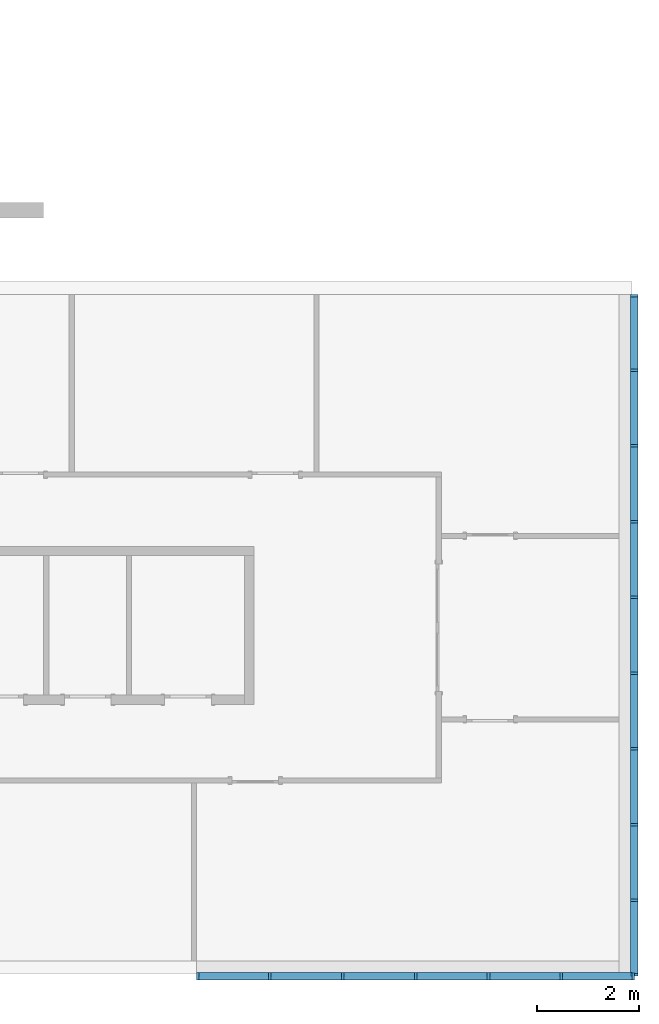
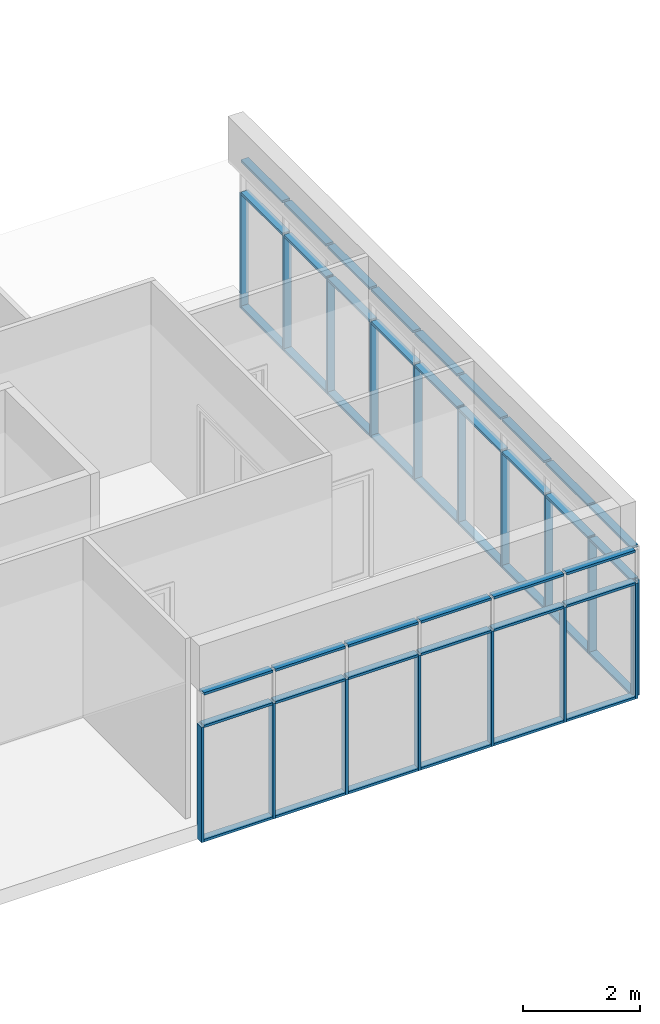
# One storey, part 2 of 11: 62 members, 2 elements without a shape of their own.
"""IFC2X3 building model written with IfcOpenShell, lengths in millimetres."""

import ifcopenshell
import ifcopenshell.guid

model = None  # the IFC model being written
_history = None  # IfcOwnerHistory: only IFC2X3 demands one
_inside = {}  # id of a spatial element -> (the spatial element, [elements in it])
_under = {}  # id of a project, library or spatial element -> (it, [spatial elements below it])
_declared = {}  # id of a project -> (the project, [libraries it declares])
_typed = {}  # id of a type object -> (the type object, [elements of that type])
_made_of = {}  # id of a material, layer set ... -> (it, [elements and type objects made of it])


def new_model(schema):
    """Start an empty IFC model of exactly this schema.

    Asked for "IFC4X3", IfcOpenShell would pick the latest addendum, in which some entities
    have other attributes; the version numbers below select the first issue.
    IFC2X3 requires an IfcOwnerHistory on every rooted entity: one is made here for all.
    """
    global model, _history
    if schema == "IFC4X3":
        model = ifcopenshell.file(schema_version=(4, 3, 0, 0))
    else:
        model = ifcopenshell.file(schema=schema)
    _inside.clear()
    _under.clear()
    _declared.clear()
    _typed.clear()
    _made_of.clear()
    _history = None
    if model.schema == "IFC2X3":
        org = make("IfcOrganization", Name="unknown")
        user = make(
            "IfcPersonAndOrganization",
            ThePerson=make("IfcPerson", FamilyName="unknown"),
            TheOrganization=org,
        )
        app = make(
            "IfcApplication",
            ApplicationDeveloper=org,
            Version="unknown",
            ApplicationFullName="unknown",
            ApplicationIdentifier="unknown",
        )
        _history = make(
            "IfcOwnerHistory",
            OwningUser=user,
            OwningApplication=app,
            ChangeAction="ADDED",
            CreationDate=0,
        )
    return model


def make(cls, **values):
    """One entity of the class cls with the attributes given. An attribute that is None is left unset."""
    return model.create_entity(
        cls, **{name: value for name, value in values.items() if value is not None}
    )


def entity(cls, *values):
    """Any entity or typed value of the class cls, its attributes in the order of the schema. None: left unset."""
    e = model.create_entity(cls)
    for i, value in enumerate(values):
        if value is not None:
            e[i] = value
    return e


def rooted(cls, **values):
    """An entity with a GlobalId (a new one), such as an element, a storey or a relation."""
    return make(cls, GlobalId=ifcopenshell.guid.new(), OwnerHistory=_history, **values)


def si_unit(unit_type, name, prefix=None):
    """IfcSIUnit, for example si_unit("LENGTHUNIT", "METRE", prefix="MILLI")."""
    return make("IfcSIUnit", UnitType=unit_type, Prefix=prefix, Name=name)


def converted_unit(unit_type, name, factor, base, dimensions=None, offset=None):
    """IfcConversionBasedUnit, such as the inch: factor (a typed value) times the base unit."""
    return make(
        "IfcConversionBasedUnit"
        if offset is None
        else "IfcConversionBasedUnitWithOffset",
        ConversionOffset=offset,
        Dimensions=None
        if dimensions is None
        else entity("IfcDimensionalExponents", *dimensions),
        UnitType=unit_type,
        Name=name,
        ConversionFactor=make(
            "IfcMeasureWithUnit", ValueComponent=factor, UnitComponent=base
        ),
    )


def assignment(units):
    """IfcUnitAssignment: the units of a project."""
    return None if units is None else make("IfcUnitAssignment", Units=units)


def point(xyz):
    """IfcCartesianPoint."""
    return None if xyz is None else make("IfcCartesianPoint", Coordinates=xyz)


def direction(xyz):
    """IfcDirection."""
    return None if xyz is None else make("IfcDirection", DirectionRatios=xyz)


def frame(location, z_axis=None, x_axis=None):
    """IfcAxis2Placement3D, a coordinate frame: its origin and axes. An axis left out is left unset."""
    return make(
        "IfcAxis2Placement3D",
        Location=point(location),
        Axis=direction(z_axis),
        RefDirection=direction(x_axis),
    )


def frame_2d(location, x_axis=None):
    """IfcAxis2Placement2D, a coordinate frame in the plane: its origin and x axis."""
    return make(
        "IfcAxis2Placement2D", Location=point(location), RefDirection=direction(x_axis)
    )


def origin():
    """The frame at (0, 0, 0) with its axes left unset."""
    return frame((0.0, 0.0, 0.0))


def origin_2d_with_axis():
    """The frame at (0, 0) in the plane with the x axis (1, 0) written out."""
    return frame_2d((0.0, 0.0), x_axis=(1.0, 0.0))


def place(relative_to, where):
    """IfcLocalPlacement: puts the frame where relative to a parent placement (None: the world)."""
    return make(
        "IfcLocalPlacement", PlacementRelTo=relative_to, RelativePlacement=where
    )


def context(
    kind, dimensions, precision=None, world=None, true_north=None, identifier=None
):
    """IfcGeometricRepresentationContext, for example the 3D "Model" context."""
    return make(
        "IfcGeometricRepresentationContext",
        ContextIdentifier=identifier,
        ContextType=kind,
        CoordinateSpaceDimension=dimensions,
        Precision=precision,
        WorldCoordinateSystem=world,
        TrueNorth=true_north,
    )


def subcontext(parent, identifier, kind, view, scale=None):
    """IfcGeometricRepresentationSubContext, for example "Body" below "Model"."""
    return make(
        "IfcGeometricRepresentationSubContext",
        ContextIdentifier=identifier,
        ContextType=kind,
        ParentContext=parent,
        TargetScale=scale,
        TargetView=view,
    )


def project(units=None, contexts=None):
    """IfcProject with its units and contexts."""
    return rooted(
        "IfcProject",
        Name="project",
        RepresentationContexts=contexts,
        UnitsInContext=assignment(units),
    )


def spatial(cls, under=None, at=None, **own):
    """A site, building, storey or space (cls), placed at a placement, below another one or the project."""
    s = rooted(cls, ObjectPlacement=at, **own)
    if under is not None:
        _under.setdefault(under.id(), (under, []))[1].append(s)
    return s


def profile(cls, at=None, kind="AREA", **sizes):
    """A parametric profile (cls). Its sizes go by their IFC names, for example OverallWidth=200.0."""
    return make(cls, ProfileType=kind, Position=at, **sizes)


def rectangle(**sizes):
    """IfcRectangleProfileDef."""
    return profile("IfcRectangleProfileDef", **sizes)


def extrude(swept, where, along, depth):
    """IfcExtrudedAreaSolid: the profile swept, set in the frame where, extruded along a direction by depth."""
    return make(
        "IfcExtrudedAreaSolid",
        SweptArea=swept,
        Position=where,
        ExtrudedDirection=direction(along),
        Depth=depth,
    )


def shape(context_of_items, identifier, shape_type, items):
    """IfcShapeRepresentation: the items that make up one representation, for example the "Body"."""
    return make(
        "IfcShapeRepresentation",
        ContextOfItems=context_of_items,
        RepresentationIdentifier=identifier,
        RepresentationType=shape_type,
        Items=items,
    )


def made_of(thing, what):
    """Note that an element or type object is made of a material, layer set ...; save() writes the relation."""
    if what is not None:
        _made_of.setdefault(what.id(), (what, []))[1].append(thing)
    return thing


def element(
    cls,
    number,
    at=None,
    inside=None,
    cuts=None,
    type_object=None,
    material=None,
    context=None,
    identifier="Body",
    shape_type=None,
    held_by="IfcProductDefinitionShape",
    body=None,
    shapes=None,
    **own,
):
    """One element of the class cls, such as IfcWall. Its Tag is "e" and its number.

    at: its placement. inside: the storey or other place that contains it. cuts: it is an
    opening in that element (IfcRelVoidsElement). A single representation is given by context,
    identifier, shape_type and body (its items); several are given by shapes. held_by: the class
    of the entity that holds the representations. save() writes the other relations.
    """
    e = rooted(cls, Tag="e%d" % number, ObjectPlacement=at, **own)
    if body is not None:
        shapes = [shape(context, identifier, shape_type, body)]
    if shapes is not None:
        e.Representation = make(held_by, Representations=shapes)
    if inside is not None:
        _inside.setdefault(inside.id(), (inside, []))[1].append(e)
    if cuts is not None:
        rooted(
            "IfcRelVoidsElement", RelatingBuildingElement=cuts, RelatedOpeningElement=e
        )
    if type_object is not None:
        _typed.setdefault(type_object.id(), (type_object, []))[1].append(e)
    return made_of(e, material)


def aggregate(whole, parts):
    """IfcRelAggregates: a whole, such as a stair, and the parts it consists of."""
    return rooted("IfcRelAggregates", RelatingObject=whole, RelatedObjects=parts)


def save(model, path):
    """Write the relations noted so far, then the file.

    IfcRelAggregates (storeys below a building ...), IfcRelContainedInSpatialStructure (elements
    in a storey), IfcRelDefinesByType, IfcRelAssociatesMaterial and IfcRelDeclares: one each for
    every whole, place, type object, material and project.
    """
    for whole, parts in _under.values():
        aggregate(whole, parts)
    for where, things in _inside.values():
        rooted(
            "IfcRelContainedInSpatialStructure",
            RelatedElements=things,
            RelatingStructure=where,
        )
    for kind, things in _typed.values():
        rooted("IfcRelDefinesByType", RelatedObjects=things, RelatingType=kind)
    for what, things in _made_of.values():
        rooted("IfcRelAssociatesMaterial", RelatedObjects=things, RelatingMaterial=what)
    for by, libraries in _declared.values():
        rooted("IfcRelDeclares", RelatingContext=by, RelatedDefinitions=libraries)
    model.write(path)


model = new_model("IFC2X3")

# Units and contexts
model_context = context("Model", 3, precision=1e-06, world=origin(), true_north=direction((2.0, 6.12303176911189e-17, 1.0)))
context_of_model = context(None, 3, precision=1e-06, world=origin(), true_north=direction((2.0, 6.12303176911189e-17, 1.0)))
body_context = subcontext(model_context, "Body", "Model", "MODEL_VIEW")
ifc_project = project(units=[si_unit("LENGTHUNIT", "METRE", prefix="MILLI"), si_unit("AREAUNIT", "SQUARE_METRE", prefix="MILLI"), si_unit("VOLUMEUNIT", "CUBIC_METRE", prefix="MILLI"), converted_unit("PLANEANGLEUNIT", "DEGREE", entity("IfcRatioMeasure", 0.0174532925199433), si_unit("PLANEANGLEUNIT", "RADIAN"), dimensions=[0, 0, 0, 0, 0, 0, 0]), si_unit("TIMEUNIT", "SECOND")], contexts=[model_context, context_of_model])

# Site, building, storey
site_placement = place(None, origin())
site = spatial("IfcSite", under=ifc_project, at=site_placement, CompositionType="ELEMENT")
building_placement = place(site_placement, origin())
building = spatial("IfcBuilding", under=site, at=building_placement, CompositionType="ELEMENT")
storey_placement = place(building_placement, frame((0.0, 0.0, 3750.0)))
storey = spatial("IfcBuildingStorey", under=building, at=storey_placement, Name="02. 2 etg.", CompositionType="ELEMENT", Elevation=3750.00000000068)

# Curtain wall, members
curtain_wall_1_placement = place(storey_placement, origin())
curtain_wall_1 = element("IfcCurtainWall", 1, at=curtain_wall_1_placement, inside=storey, Name="Curtain Wall:Storefront", ObjectType="Curtain Wall:Storefront")
member_1_placement = place(storey_placement, origin())
member_1 = element("IfcMember", 2, at=member_1_placement, Name="Curtain Wall:Storefront:8486", ObjectType="Curtain Wall:Storefront:8486", context=body_context, shape_type="SweptSolid", body=[
    extrude(rectangle(XDim=1411.66666666667, YDim=150.000000000001, at=frame_2d((0.0, 4.32720526077901e-12), x_axis=(1.0, 0.0))), frame((41098.2357123495, -12684.1666666667, 2750.0), z_axis=(0.0, 0.0, 1.0), x_axis=(0.0, 1.0, 0.0)), (0.0, 0.0, 1.0), 49.9999999999995),
])
member_2_placement = place(storey_placement, origin())
member_2 = element("IfcMember", 3, at=member_2_placement, Name="Curtain Wall:Storefront:8486", ObjectType="Curtain Wall:Storefront:8486", context=body_context, shape_type="SweptSolid", body=[
    extrude(rectangle(XDim=1411.66666666667, YDim=150.000000000001, at=origin_2d_with_axis()), frame((41098.2357123495, -815.833333333333, -300.0), z_axis=(0.0, 0.0, 1.0), x_axis=(0.0, -1.0, 0.0)), (0.0, 0.0, 1.0), 50.0),
])
member_3_placement = place(storey_placement, origin())
member_3 = element("IfcMember", 4, at=member_3_placement, Name="Curtain Wall:Storefront:8486", ObjectType="Curtain Wall:Storefront:8486", context=body_context, shape_type="SweptSolid", body=[
    extrude(rectangle(XDim=150.000000000001, YDim=50.0000000000016, at=origin_2d_with_axis()), frame((41098.2357123495, -13415.0, -300.0)), (0.0, 0.0, 1.0), 2400.0),
])
member_4_placement = place(storey_placement, origin())
member_4 = element("IfcMember", 5, at=member_4_placement, Name="Curtain Wall:Storefront:8486", ObjectType="Curtain Wall:Storefront:8486", context=body_context, shape_type="SweptSolid", body=[
    extrude(rectangle(XDim=1411.66666666667, YDim=150.000000000001, at=origin_2d_with_axis()), frame((41098.2357123495, -815.83333333333, 2750.0), z_axis=(0.0, 0.0, 1.0), x_axis=(0.0, 1.0, 0.0)), (0.0, 0.0, 1.0), 49.9999999999995),
])
member_5_placement = place(storey_placement, origin())
member_5 = element("IfcMember", 6, at=member_5_placement, Name="Curtain Wall:Storefront:8486", ObjectType="Curtain Wall:Storefront:8486", context=body_context, shape_type="SweptSolid", body=[
    extrude(rectangle(XDim=1436.66666666667, YDim=150.000000000001, at=frame_2d((0.0, 4.32720526077901e-12), x_axis=(1.0, 0.0))), frame((41098.2357123495, -2290.0, 2750.0), z_axis=(0.0, 0.0, 1.0), x_axis=(0.0, 1.0, 0.0)), (0.0, 0.0, 1.0), 49.9999999999995),
])
member_6_placement = place(storey_placement, origin())
member_6 = element("IfcMember", 7, at=member_6_placement, Name="Curtain Wall:Storefront:8486", ObjectType="Curtain Wall:Storefront:8486", context=body_context, shape_type="SweptSolid", body=[
    extrude(rectangle(XDim=1436.66666666667, YDim=150.000000000001, at=origin_2d_with_axis()), frame((41098.2357123495, -3776.66666666667, 2750.0), z_axis=(0.0, 0.0, 1.0), x_axis=(0.0, 1.0, 0.0)), (0.0, 0.0, 1.0), 49.9999999999995),
])
member_7_placement = place(storey_placement, origin())
member_7 = element("IfcMember", 8, at=member_7_placement, Name="Curtain Wall:Storefront:8486", ObjectType="Curtain Wall:Storefront:8486", context=body_context, shape_type="SweptSolid", body=[
    extrude(rectangle(XDim=1436.66666666667, YDim=150.000000000001, at=frame_2d((-5.11590769747272e-13, 0.0), x_axis=(1.0, 0.0))), frame((41098.2357123495, -5263.33333333333, 2750.0), z_axis=(0.0, 0.0, 1.0), x_axis=(0.0, 1.0, 0.0)), (0.0, 0.0, 1.0), 49.9999999999995),
])
member_8_placement = place(storey_placement, origin())
member_8 = element("IfcMember", 9, at=member_8_placement, Name="Curtain Wall:Storefront:8486", ObjectType="Curtain Wall:Storefront:8486", context=body_context, shape_type="SweptSolid", body=[
    extrude(rectangle(XDim=1436.66666666667, YDim=150.000000000001, at=frame_2d((-5.11590769747272e-13, 0.0), x_axis=(1.0, 0.0))), frame((41098.2357123495, -6750.0, 2750.0), z_axis=(0.0, 0.0, 1.0), x_axis=(0.0, 1.0, 0.0)), (0.0, 0.0, 1.0), 49.9999999999995),
])
member_9_placement = place(storey_placement, origin())
member_9 = element("IfcMember", 10, at=member_9_placement, Name="Curtain Wall:Storefront:8486", ObjectType="Curtain Wall:Storefront:8486", context=body_context, shape_type="SweptSolid", body=[
    extrude(rectangle(XDim=1436.66666666667, YDim=150.000000000001, at=frame_2d((5.6843418860808e-13, -4.32720526077901e-12), x_axis=(1.0, 0.0))), frame((41098.2357123495, -8236.66666666667, 2750.0), z_axis=(0.0, 0.0, 1.0), x_axis=(0.0, 1.0, 0.0)), (0.0, 0.0, 1.0), 49.9999999999995),
])
member_10_placement = place(storey_placement, origin())
member_10 = element("IfcMember", 11, at=member_10_placement, Name="Curtain Wall:Storefront:8486", ObjectType="Curtain Wall:Storefront:8486", context=body_context, shape_type="SweptSolid", body=[
    extrude(rectangle(XDim=1436.66666666667, YDim=150.000000000001, at=frame_2d((-5.11590769747272e-13, 0.0), x_axis=(1.0, 0.0))), frame((41098.2357123495, -9723.33333333333, 2750.0), z_axis=(0.0, 0.0, 1.0), x_axis=(0.0, 1.0, 0.0)), (0.0, 0.0, 1.0), 49.9999999999995),
])
member_11_placement = place(storey_placement, origin())
member_11 = element("IfcMember", 12, at=member_11_placement, Name="Curtain Wall:Storefront:8486", ObjectType="Curtain Wall:Storefront:8486", context=body_context, shape_type="SweptSolid", body=[
    extrude(rectangle(XDim=1436.66666666667, YDim=150.000000000001, at=origin_2d_with_axis()), frame((41098.2357123495, -11210.0, 2750.0), z_axis=(0.0, 0.0, 1.0), x_axis=(0.0, 1.0, 0.0)), (0.0, 0.0, 1.0), 49.9999999999995),
])
member_12_placement = place(storey_placement, origin())
member_12 = element("IfcMember", 13, at=member_12_placement, Name="Curtain Wall:Storefront:8486", ObjectType="Curtain Wall:Storefront:8486", context=body_context, shape_type="SweptSolid", body=[
    extrude(rectangle(XDim=1436.66666666667, YDim=150.000000000001, at=frame_2d((0.0, -4.32720526077901e-12), x_axis=(1.0, 0.0))), frame((41098.2357123495, -2290.0, -300.0), z_axis=(0.0, 0.0, 1.0), x_axis=(0.0, -1.0, 0.0)), (0.0, 0.0, 1.0), 50.0),
])
member_13_placement = place(storey_placement, origin())
member_13 = element("IfcMember", 14, at=member_13_placement, Name="Curtain Wall:Storefront:8486", ObjectType="Curtain Wall:Storefront:8486", context=body_context, shape_type="SweptSolid", body=[
    extrude(rectangle(XDim=1436.66666666667, YDim=150.000000000001, at=origin_2d_with_axis()), frame((41098.2357123495, -3776.66666666667, -300.0), z_axis=(0.0, 0.0, 1.0), x_axis=(0.0, -1.0, 0.0)), (0.0, 0.0, 1.0), 50.0),
])
member_14_placement = place(storey_placement, origin())
member_14 = element("IfcMember", 15, at=member_14_placement, Name="Curtain Wall:Storefront:8486", ObjectType="Curtain Wall:Storefront:8486", context=body_context, shape_type="SweptSolid", body=[
    extrude(rectangle(XDim=1436.66666666667, YDim=150.000000000001, at=origin_2d_with_axis()), frame((41098.2357123495, -5263.33333333333, -300.0), z_axis=(0.0, 0.0, 1.0), x_axis=(0.0, -1.0, 0.0)), (0.0, 0.0, 1.0), 50.0),
])
member_15_placement = place(storey_placement, origin())
member_15 = element("IfcMember", 16, at=member_15_placement, Name="Curtain Wall:Storefront:8486", ObjectType="Curtain Wall:Storefront:8486", context=body_context, shape_type="SweptSolid", body=[
    extrude(rectangle(XDim=1436.66666666667, YDim=150.000000000001, at=origin_2d_with_axis()), frame((41098.2357123495, -6750.0, -300.0), z_axis=(0.0, 0.0, 1.0), x_axis=(0.0, -1.0, 0.0)), (0.0, 0.0, 1.0), 50.0),
])
member_16_placement = place(storey_placement, origin())
member_16 = element("IfcMember", 17, at=member_16_placement, Name="Curtain Wall:Storefront:8486", ObjectType="Curtain Wall:Storefront:8486", context=body_context, shape_type="SweptSolid", body=[
    extrude(rectangle(XDim=1436.66666666667, YDim=150.000000000001, at=frame_2d((5.11590769747272e-13, 4.32720526077901e-12), x_axis=(1.0, 0.0))), frame((41098.2357123495, -8236.66666666667, -300.0), z_axis=(0.0, 0.0, 1.0), x_axis=(0.0, -1.0, 0.0)), (0.0, 0.0, 1.0), 50.0),
])
member_17_placement = place(storey_placement, origin())
member_17 = element("IfcMember", 18, at=member_17_placement, Name="Curtain Wall:Storefront:8486", ObjectType="Curtain Wall:Storefront:8486", context=body_context, shape_type="SweptSolid", body=[
    extrude(rectangle(XDim=1436.66666666667, YDim=150.000000000001, at=frame_2d((1.08002495835535e-12, 0.0), x_axis=(1.0, 0.0))), frame((41098.2357123495, -9723.33333333333, -300.0), z_axis=(0.0, 0.0, 1.0), x_axis=(0.0, -1.0, 0.0)), (0.0, 0.0, 1.0), 50.0),
])
member_18_placement = place(storey_placement, origin())
member_18 = element("IfcMember", 19, at=member_18_placement, Name="Curtain Wall:Storefront:8486", ObjectType="Curtain Wall:Storefront:8486", context=body_context, shape_type="SweptSolid", body=[
    extrude(rectangle(XDim=1436.66666666667, YDim=150.000000000001, at=frame_2d((-1.08002495835535e-12, 0.0), x_axis=(1.0, 0.0))), frame((41098.2357123495, -11210.0, -300.0), z_axis=(0.0, 0.0, 1.0), x_axis=(0.0, -1.0, 0.0)), (0.0, 0.0, 1.0), 50.0),
])
member_19_placement = place(storey_placement, origin())
member_19 = element("IfcMember", 20, at=member_19_placement, Name="Curtain Wall:Storefront:8486", ObjectType="Curtain Wall:Storefront:8486", context=body_context, shape_type="SweptSolid", body=[
    extrude(rectangle(XDim=1411.66666666667, YDim=150.000000000001, at=frame_2d((0.0, -4.32720526077901e-12), x_axis=(1.0, 0.0))), frame((41098.2357123495, -12684.1666666667, -300.0), z_axis=(0.0, 0.0, 1.0), x_axis=(0.0, -1.0, 0.0)), (0.0, 0.0, 1.0), 50.0),
])
member_20_placement = place(storey_placement, origin())
member_20 = element("IfcMember", 21, at=member_20_placement, Name="Curtain Wall:Storefront:8486", ObjectType="Curtain Wall:Storefront:8486", context=body_context, shape_type="SweptSolid", body=[
    extrude(rectangle(XDim=50.0, YDim=150.000000000001, at=frame_2d((3.5527136788005e-15, 0.0), x_axis=(1.0, 0.0))), frame((41098.2357123495, -85.0, -300.0), z_axis=(0.0, 0.0, 1.0), x_axis=(0.0, -1.0, 0.0)), (0.0, 0.0, 1.0), 2400.0),
])
member_21_placement = place(storey_placement, origin())
member_21 = element("IfcMember", 22, at=member_21_placement, Name="Curtain Wall:Storefront:8486", ObjectType="Curtain Wall:Storefront:8486", context=body_context, shape_type="SweptSolid", body=[
    extrude(rectangle(XDim=1411.66666666667, YDim=150.000000000001, at=origin_2d_with_axis()), frame((41098.2357123495, -815.833333333332, 2075.0), z_axis=(0.0, 0.0, 1.0), x_axis=(0.0, 1.0, 0.0)), (0.0, 0.0, 1.0), 49.9999999999995),
])
member_22_placement = place(storey_placement, origin())
member_22 = element("IfcMember", 23, at=member_22_placement, Name="Curtain Wall:Storefront:8486", ObjectType="Curtain Wall:Storefront:8486", context=body_context, shape_type="SweptSolid", body=[
    extrude(rectangle(XDim=1436.66666666667, YDim=150.000000000001, at=frame_2d((1.13686837721616e-13, 4.32720526077901e-12), x_axis=(1.0, 0.0))), frame((41098.2357123495, -2290.0, 2075.0), z_axis=(0.0, 0.0, 1.0), x_axis=(0.0, 1.0, 0.0)), (0.0, 0.0, 1.0), 49.9999999999995),
])
member_23_placement = place(storey_placement, origin())
member_23 = element("IfcMember", 24, at=member_23_placement, Name="Curtain Wall:Storefront:8486", ObjectType="Curtain Wall:Storefront:8486", context=body_context, shape_type="SweptSolid", body=[
    extrude(rectangle(XDim=1436.66666666667, YDim=150.000000000001, at=origin_2d_with_axis()), frame((41098.2357123495, -3776.66666666667, 2075.0), z_axis=(0.0, 0.0, 1.0), x_axis=(0.0, 1.0, 0.0)), (0.0, 0.0, 1.0), 49.9999999999995),
])
member_24_placement = place(storey_placement, origin())
member_24 = element("IfcMember", 25, at=member_24_placement, Name="Curtain Wall:Storefront:8486", ObjectType="Curtain Wall:Storefront:8486", context=body_context, shape_type="SweptSolid", body=[
    extrude(rectangle(XDim=1436.66666666667, YDim=150.000000000001, at=frame_2d((-5.11590769747272e-13, 0.0), x_axis=(1.0, 0.0))), frame((41098.2357123495, -5263.33333333333, 2075.0), z_axis=(0.0, 0.0, 1.0), x_axis=(0.0, 1.0, 0.0)), (0.0, 0.0, 1.0), 49.9999999999995),
])
member_25_placement = place(storey_placement, origin())
member_25 = element("IfcMember", 26, at=member_25_placement, Name="Curtain Wall:Storefront:8486", ObjectType="Curtain Wall:Storefront:8486", context=body_context, shape_type="SweptSolid", body=[
    extrude(rectangle(XDim=1436.66666666667, YDim=150.000000000001, at=frame_2d((5.11590769747272e-13, 0.0), x_axis=(1.0, 0.0))), frame((41098.2357123495, -6750.0, 2075.0), z_axis=(0.0, 0.0, 1.0), x_axis=(0.0, 1.0, 0.0)), (0.0, 0.0, 1.0), 49.9999999999995),
])
member_26_placement = place(storey_placement, origin())
member_26 = element("IfcMember", 27, at=member_26_placement, Name="Curtain Wall:Storefront:8486", ObjectType="Curtain Wall:Storefront:8486", context=body_context, shape_type="SweptSolid", body=[
    extrude(rectangle(XDim=1436.66666666667, YDim=150.000000000001, at=frame_2d((5.6843418860808e-13, -4.32720526077901e-12), x_axis=(1.0, 0.0))), frame((41098.2357123495, -8236.66666666667, 2075.0), z_axis=(0.0, 0.0, 1.0), x_axis=(0.0, 1.0, 0.0)), (0.0, 0.0, 1.0), 49.9999999999995),
])
member_27_placement = place(storey_placement, origin())
member_27 = element("IfcMember", 28, at=member_27_placement, Name="Curtain Wall:Storefront:8486", ObjectType="Curtain Wall:Storefront:8486", context=body_context, shape_type="SweptSolid", body=[
    extrude(rectangle(XDim=1436.66666666667, YDim=150.000000000001, at=frame_2d((-5.11590769747272e-13, 0.0), x_axis=(1.0, 0.0))), frame((41098.2357123495, -9723.33333333333, 2075.0), z_axis=(0.0, 0.0, 1.0), x_axis=(0.0, 1.0, 0.0)), (0.0, 0.0, 1.0), 49.9999999999995),
])
member_28_placement = place(storey_placement, origin())
member_28 = element("IfcMember", 29, at=member_28_placement, Name="Curtain Wall:Storefront:8486", ObjectType="Curtain Wall:Storefront:8486", context=body_context, shape_type="SweptSolid", body=[
    extrude(rectangle(XDim=1436.66666666667, YDim=150.000000000001, at=frame_2d((-1.08002495835535e-12, 0.0), x_axis=(1.0, 0.0))), frame((41098.2357123495, -11210.0, 2075.0), z_axis=(0.0, 0.0, 1.0), x_axis=(0.0, 1.0, 0.0)), (0.0, 0.0, 1.0), 49.9999999999995),
])
member_29_placement = place(storey_placement, origin())
member_29 = element("IfcMember", 30, at=member_29_placement, Name="Curtain Wall:Storefront:8486", ObjectType="Curtain Wall:Storefront:8486", context=body_context, shape_type="SweptSolid", body=[
    extrude(rectangle(XDim=1411.66666666667, YDim=150.000000000001, at=frame_2d((0.0, 4.32720526077901e-12), x_axis=(1.0, 0.0))), frame((41098.2357123495, -12684.1666666667, 2075.0), z_axis=(0.0, 0.0, 1.0), x_axis=(0.0, 1.0, 0.0)), (0.0, 0.0, 1.0), 49.9999999999995),
])
member_30_placement = place(storey_placement, origin())
member_30 = element("IfcMember", 31, at=member_30_placement, Name="Curtain Wall:Storefront:8486", ObjectType="Curtain Wall:Storefront:8486", context=body_context, shape_type="SweptSolid", body=[
    extrude(rectangle(XDim=150.000000000001, YDim=50.0, at=frame_2d((0.0, -1.36779476633819e-13), x_axis=(1.0, 0.0))), frame((41098.2357123495, -1546.66666666667, -300.0)), (0.0, 0.0, 1.0), 2400.0),
])
member_31_placement = place(storey_placement, origin())
member_31 = element("IfcMember", 32, at=member_31_placement, Name="Curtain Wall:Storefront:8486", ObjectType="Curtain Wall:Storefront:8486", context=body_context, shape_type="SweptSolid", body=[
    extrude(rectangle(XDim=150.000000000001, YDim=50.0, at=frame_2d((0.0, 2.71782596428238e-13), x_axis=(1.0, 0.0))), frame((41098.2357123495, -3033.33333333333, -300.0)), (0.0, 0.0, 1.0), 2400.0),
])
member_32_placement = place(storey_placement, origin())
member_32 = element("IfcMember", 33, at=member_32_placement, Name="Curtain Wall:Storefront:8486", ObjectType="Curtain Wall:Storefront:8486", context=body_context, shape_type="SweptSolid", body=[
    extrude(rectangle(XDim=150.000000000001, YDim=50.0, at=frame_2d((0.0, -2.71782596428238e-13), x_axis=(1.0, 0.0))), frame((41098.2357123495, -4520.0, -300.0)), (0.0, 0.0, 1.0), 2400.0),
])
member_33_placement = place(storey_placement, origin())
member_33 = element("IfcMember", 34, at=member_33_placement, Name="Curtain Wall:Storefront:8486", ObjectType="Curtain Wall:Storefront:8486", context=body_context, shape_type="SweptSolid", body=[
    extrude(rectangle(XDim=150.000000000001, YDim=50.0000000000005, at=frame_2d((0.0, -5.41788836017076e-13), x_axis=(1.0, 0.0))), frame((41098.2357123495, -6006.66666666667, -300.0)), (0.0, 0.0, 1.0), 2400.0),
])
member_34_placement = place(storey_placement, origin())
member_34 = element("IfcMember", 35, at=member_34_placement, Name="Curtain Wall:Storefront:8486", ObjectType="Curtain Wall:Storefront:8486", context=body_context, shape_type="SweptSolid", body=[
    extrude(rectangle(XDim=150.000000000001, YDim=50.0000000000005, at=frame_2d((0.0, 5.41788836017076e-13), x_axis=(1.0, 0.0))), frame((41098.2357123495, -7493.33333333333, -300.0)), (0.0, 0.0, 1.0), 2400.0),
])
member_35_placement = place(storey_placement, origin())
member_35 = element("IfcMember", 36, at=member_35_placement, Name="Curtain Wall:Storefront:8486", ObjectType="Curtain Wall:Storefront:8486", context=body_context, shape_type="SweptSolid", body=[
    extrude(rectangle(XDim=150.000000000001, YDim=50.0000000000005, at=frame_2d((0.0, -5.41788836017076e-13), x_axis=(1.0, 0.0))), frame((41098.2357123495, -8980.0, -300.0)), (0.0, 0.0, 1.0), 2400.0),
])
member_36_placement = place(storey_placement, origin())
member_36 = element("IfcMember", 37, at=member_36_placement, Name="Curtain Wall:Storefront:8486", ObjectType="Curtain Wall:Storefront:8486", context=body_context, shape_type="SweptSolid", body=[
    extrude(rectangle(XDim=150.000000000001, YDim=49.9999999999995, at=frame_2d((0.0, -1.08357767203415e-12), x_axis=(1.0, 0.0))), frame((41098.2357123495, -10466.6666666667, -300.0)), (0.0, 0.0, 1.0), 2400.0),
])
member_37_placement = place(storey_placement, origin())
member_37 = element("IfcMember", 38, at=member_37_placement, Name="Curtain Wall:Storefront:8486", ObjectType="Curtain Wall:Storefront:8486", context=body_context, shape_type="SweptSolid", body=[
    extrude(rectangle(XDim=150.000000000001, YDim=49.9999999999995, at=frame_2d((0.0, -1.08357767203415e-12), x_axis=(1.0, 0.0))), frame((41098.2357123495, -11953.3333333333, -300.0)), (0.0, 0.0, 1.0), 2400.0),
])
aggregate(curtain_wall_1, [member_1, member_2, member_3, member_4, member_5, member_6, member_7, member_8, member_9, member_10, member_11, member_12, member_13, member_14, member_15, member_16, member_17, member_18, member_19, member_20, member_21, member_22, member_23, member_24, member_25, member_26, member_27, member_28, member_29, member_30, member_31, member_32, member_33, member_34, member_35, member_36, member_37])

curtain_wall_2_placement = place(storey_placement, origin())
curtain_wall_2 = element("IfcCurtainWall", 39, at=curtain_wall_2_placement, inside=storey, Name="Curtain Wall:Storefront", ObjectType="Curtain Wall:Storefront")
member_38_placement = place(storey_placement, origin())
member_38 = element("IfcMember", 40, at=member_38_placement, Name="Curtain Wall:Storefront:8486", ObjectType="Curtain Wall:Storefront:8486", context=body_context, shape_type="SweptSolid", body=[
    extrude(rectangle(XDim=1356.66666666667, YDim=150.000000000001, at=origin_2d_with_axis()), frame((33236.5690456828, -13440.0, 2750.0)), (0.0, 0.0, 1.0), 49.9999999999995),
])
member_39_placement = place(storey_placement, origin())
member_39 = element("IfcMember", 41, at=member_39_placement, Name="Curtain Wall:Storefront:8486", ObjectType="Curtain Wall:Storefront:8486", context=body_context, shape_type="SweptSolid", body=[
    extrude(rectangle(XDim=1356.66666666667, YDim=150.000000000001, at=frame_2d((0.0, 2.16715534406831e-12), x_axis=(1.0, 0.0))), frame((40369.9023790162, -13440.0, -300.0), z_axis=(0.0, 0.0, 1.0), x_axis=(-1.0, 0.0, 0.0)), (0.0, 0.0, 1.0), 50.0),
])
member_40_placement = place(storey_placement, origin())
member_40 = element("IfcMember", 42, at=member_40_placement, Name="Curtain Wall:Storefront:8486", ObjectType="Curtain Wall:Storefront:8486", context=body_context, shape_type="SweptSolid", body=[
    extrude(rectangle(XDim=149.999999999998, YDim=50.0000000000016, at=frame_2d((-1.08002495835535e-12, -2.16715534406831e-12), x_axis=(1.0, 0.0))), frame((32533.2357123495, -13440.0, -300.0), z_axis=(0.0, 0.0, 1.0), x_axis=(0.0, -1.0, 0.0)), (0.0, 0.0, 1.0), 2400.0),
])
member_41_placement = place(storey_placement, origin())
member_41 = element("IfcMember", 43, at=member_41_placement, Name="Curtain Wall:Storefront:8486", ObjectType="Curtain Wall:Storefront:8486", context=body_context, shape_type="SweptSolid", body=[
    extrude(rectangle(XDim=1356.66666666667, YDim=150.000000000001, at=origin_2d_with_axis()), frame((40369.9023790162, -13440.0, 2750.0)), (0.0, 0.0, 1.0), 49.9999999999995),
])
member_42_placement = place(storey_placement, origin())
member_42 = element("IfcMember", 44, at=member_42_placement, Name="Curtain Wall:Storefront:8486", ObjectType="Curtain Wall:Storefront:8486", context=body_context, shape_type="SweptSolid", body=[
    extrude(rectangle(XDim=1381.66666666667, YDim=150.000000000001, at=frame_2d((-2.1600499167107e-12, 2.16715534406831e-12), x_axis=(1.0, 0.0))), frame((38950.7357123495, -13440.0, 2750.0)), (0.0, 0.0, 1.0), 49.9999999999995),
])
member_43_placement = place(storey_placement, origin())
member_43 = element("IfcMember", 45, at=member_43_placement, Name="Curtain Wall:Storefront:8486", ObjectType="Curtain Wall:Storefront:8486", context=body_context, shape_type="SweptSolid", body=[
    extrude(rectangle(XDim=1381.66666666667, YDim=150.000000000001, at=frame_2d((-2.1600499167107e-12, 0.0), x_axis=(1.0, 0.0))), frame((37519.0690456828, -13440.0, 2750.0)), (0.0, 0.0, 1.0), 49.9999999999995),
])
member_44_placement = place(storey_placement, origin())
member_44 = element("IfcMember", 46, at=member_44_placement, Name="Curtain Wall:Storefront:8486", ObjectType="Curtain Wall:Storefront:8486", context=body_context, shape_type="SweptSolid", body=[
    extrude(rectangle(XDim=1381.66666666667, YDim=150.000000000001, at=frame_2d((-2.1600499167107e-12, 0.0), x_axis=(1.0, 0.0))), frame((38950.7357123495, -13440.0, -300.0), z_axis=(0.0, 0.0, 1.0), x_axis=(-1.0, 0.0, 0.0)), (0.0, 0.0, 1.0), 50.0),
])
member_45_placement = place(storey_placement, origin())
member_45 = element("IfcMember", 47, at=member_45_placement, Name="Curtain Wall:Storefront:8486", ObjectType="Curtain Wall:Storefront:8486", context=body_context, shape_type="SweptSolid", body=[
    extrude(rectangle(XDim=1381.66666666667, YDim=150.000000000001, at=frame_2d((2.1600499167107e-12, -2.16715534406831e-12), x_axis=(1.0, 0.0))), frame((37519.0690456828, -13440.0, -300.0), z_axis=(0.0, 0.0, 1.0), x_axis=(-1.0, 0.0, 0.0)), (0.0, 0.0, 1.0), 50.0),
])
member_46_placement = place(storey_placement, origin())
member_46 = element("IfcMember", 48, at=member_46_placement, Name="Curtain Wall:Storefront:8486", ObjectType="Curtain Wall:Storefront:8486", context=body_context, shape_type="SweptSolid", body=[
    extrude(rectangle(XDim=1381.66666666667, YDim=150.000000000001, at=frame_2d((2.1600499167107e-12, -1.08713038571295e-12), x_axis=(1.0, 0.0))), frame((36087.4023790162, -13440.0, -300.0), z_axis=(0.0, 0.0, 1.0), x_axis=(-1.0, 0.0, 0.0)), (0.0, 0.0, 1.0), 50.0),
])
member_47_placement = place(storey_placement, origin())
member_47 = element("IfcMember", 49, at=member_47_placement, Name="Curtain Wall:Storefront:8486", ObjectType="Curtain Wall:Storefront:8486", context=body_context, shape_type="SweptSolid", body=[
    extrude(rectangle(XDim=49.9999999999973, YDim=150.000000000001, at=frame_2d((4.33253433129721e-12, 0.0), x_axis=(1.0, 0.0))), frame((41073.2357123495, -13440.0, -300.0), z_axis=(0.0, 0.0, 1.0), x_axis=(-1.0, 0.0, 0.0)), (0.0, 0.0, 1.0), 2400.0),
])
member_48_placement = place(storey_placement, origin())
member_48 = element("IfcMember", 50, at=member_48_placement, Name="Curtain Wall:Storefront:8486", ObjectType="Curtain Wall:Storefront:8486", context=body_context, shape_type="SweptSolid", body=[
    extrude(rectangle(XDim=1356.66666666667, YDim=150.000000000001, at=origin_2d_with_axis()), frame((40369.9023790162, -13440.0, 2075.0)), (0.0, 0.0, 1.0), 49.9999999999995),
])
member_49_placement = place(storey_placement, origin())
member_49 = element("IfcMember", 51, at=member_49_placement, Name="Curtain Wall:Storefront:8486", ObjectType="Curtain Wall:Storefront:8486", context=body_context, shape_type="SweptSolid", body=[
    extrude(rectangle(XDim=1381.66666666667, YDim=150.000000000001, at=frame_2d((-2.1600499167107e-12, 2.16715534406831e-12), x_axis=(1.0, 0.0))), frame((38950.7357123495, -13440.0, 2075.0)), (0.0, 0.0, 1.0), 49.9999999999995),
])
member_50_placement = place(storey_placement, origin())
member_50 = element("IfcMember", 52, at=member_50_placement, Name="Curtain Wall:Storefront:8486", ObjectType="Curtain Wall:Storefront:8486", context=body_context, shape_type="SweptSolid", body=[
    extrude(rectangle(XDim=1381.66666666667, YDim=150.000000000001, at=frame_2d((-2.1600499167107e-12, 0.0), x_axis=(1.0, 0.0))), frame((37519.0690456828, -13440.0, 2075.0)), (0.0, 0.0, 1.0), 49.9999999999995),
])
member_51_placement = place(storey_placement, origin())
member_51 = element("IfcMember", 53, at=member_51_placement, Name="Curtain Wall:Storefront:8486", ObjectType="Curtain Wall:Storefront:8486", context=body_context, shape_type="SweptSolid", body=[
    extrude(rectangle(XDim=1381.66666666667, YDim=149.999999999998, at=frame_2d((-2.1600499167107e-12, 0.0), x_axis=(1.0, 0.0))), frame((36087.4023790161, -13440.0, 2075.0)), (0.0, 0.0, 1.0), 49.9999999999995),
])
member_52_placement = place(storey_placement, origin())
member_52 = element("IfcMember", 54, at=member_52_placement, Name="Curtain Wall:Storefront:8486", ObjectType="Curtain Wall:Storefront:8486", context=body_context, shape_type="SweptSolid", body=[
    extrude(rectangle(XDim=149.999999999998, YDim=50.000000000006, at=frame_2d((1.08002495835535e-12, 0.0), x_axis=(1.0, 0.0))), frame((39666.5690456828, -13440.0, -300.0), z_axis=(0.0, 0.0, 1.0), x_axis=(0.0, -1.0, 0.0)), (0.0, 0.0, 1.0), 2400.0),
])
member_53_placement = place(storey_placement, origin())
member_53 = element("IfcMember", 55, at=member_53_placement, Name="Curtain Wall:Storefront:8486", ObjectType="Curtain Wall:Storefront:8486", context=body_context, shape_type="SweptSolid", body=[
    extrude(rectangle(XDim=149.999999999998, YDim=49.9999999999973, at=frame_2d((1.08002495835535e-12, 2.16715534406831e-12), x_axis=(1.0, 0.0))), frame((38234.9023790161, -13440.0, -300.0), z_axis=(0.0, 0.0, 1.0), x_axis=(0.0, -1.0, 0.0)), (0.0, 0.0, 1.0), 2400.0),
])
member_54_placement = place(storey_placement, origin())
member_54 = element("IfcMember", 56, at=member_54_placement, Name="Curtain Wall:Storefront:8486", ObjectType="Curtain Wall:Storefront:8486", context=body_context, shape_type="SweptSolid", body=[
    extrude(rectangle(XDim=149.999999999998, YDim=49.9999999999973, at=frame_2d((1.08002495835535e-12, 2.16715534406831e-12), x_axis=(1.0, 0.0))), frame((36803.2357123495, -13440.0, -300.0), z_axis=(0.0, 0.0, 1.0), x_axis=(0.0, -1.0, 0.0)), (0.0, 0.0, 1.0), 2400.0),
])
member_55_placement = place(storey_placement, origin())
member_55 = element("IfcMember", 57, at=member_55_placement, Name="Curtain Wall:Storefront:8486", ObjectType="Curtain Wall:Storefront:8486", context=body_context, shape_type="SweptSolid", body=[
    extrude(rectangle(XDim=1381.66666666667, YDim=150.000000000001, at=frame_2d((-2.1600499167107e-12, 1.08713038571295e-12), x_axis=(1.0, 0.0))), frame((36087.4023790161, -13440.0, 2750.0)), (0.0, 0.0, 1.0), 49.9999999999995),
])
member_56_placement = place(storey_placement, origin())
member_56 = element("IfcMember", 58, at=member_56_placement, Name="Curtain Wall:Storefront:8486", ObjectType="Curtain Wall:Storefront:8486", context=body_context, shape_type="SweptSolid", body=[
    extrude(rectangle(XDim=1381.66666666667, YDim=150.000000000001, at=frame_2d((2.1600499167107e-12, 0.0), x_axis=(1.0, 0.0))), frame((34655.7357123495, -13440.0, -300.0), z_axis=(0.0, 0.0, 1.0), x_axis=(-1.0, 0.0, 0.0)), (0.0, 0.0, 1.0), 50.0),
])
member_57_placement = place(storey_placement, origin())
member_57 = element("IfcMember", 59, at=member_57_placement, Name="Curtain Wall:Storefront:8486", ObjectType="Curtain Wall:Storefront:8486", context=body_context, shape_type="SweptSolid", body=[
    extrude(rectangle(XDim=1381.66666666667, YDim=149.999999999998, at=frame_2d((-2.1600499167107e-12, -1.08002495835535e-12), x_axis=(1.0, 0.0))), frame((34655.7357123495, -13440.0, 2075.0)), (0.0, 0.0, 1.0), 49.9999999999995),
])
member_58_placement = place(storey_placement, origin())
member_58 = element("IfcMember", 60, at=member_58_placement, Name="Curtain Wall:Storefront:8486", ObjectType="Curtain Wall:Storefront:8486", context=body_context, shape_type="SweptSolid", body=[
    extrude(rectangle(XDim=149.999999999998, YDim=49.9999999999973, at=frame_2d((-1.08002495835535e-12, 2.16715534406831e-12), x_axis=(1.0, 0.0))), frame((35371.5690456828, -13440.0, -300.0), z_axis=(0.0, 0.0, 1.0), x_axis=(0.0, -1.0, 0.0)), (0.0, 0.0, 1.0), 2400.0),
])
member_59_placement = place(storey_placement, origin())
member_59 = element("IfcMember", 61, at=member_59_placement, Name="Curtain Wall:Storefront:8486", ObjectType="Curtain Wall:Storefront:8486", context=body_context, shape_type="SweptSolid", body=[
    extrude(rectangle(XDim=1381.66666666667, YDim=150.000000000001, at=frame_2d((-2.1600499167107e-12, 0.0), x_axis=(1.0, 0.0))), frame((34655.7357123495, -13440.0, 2750.0)), (0.0, 0.0, 1.0), 49.9999999999995),
])
member_60_placement = place(storey_placement, origin())
member_60 = element("IfcMember", 62, at=member_60_placement, Name="Curtain Wall:Storefront:8486", ObjectType="Curtain Wall:Storefront:8486", context=body_context, shape_type="SweptSolid", body=[
    extrude(rectangle(XDim=1356.66666666667, YDim=150.000000000001, at=origin_2d_with_axis()), frame((33236.5690456828, -13440.0, -300.0), z_axis=(0.0, 0.0, 1.0), x_axis=(-1.0, 0.0, 0.0)), (0.0, 0.0, 1.0), 50.0),
])
member_61_placement = place(storey_placement, origin())
member_61 = element("IfcMember", 63, at=member_61_placement, Name="Curtain Wall:Storefront:8486", ObjectType="Curtain Wall:Storefront:8486", context=body_context, shape_type="SweptSolid", body=[
    extrude(rectangle(XDim=1356.66666666667, YDim=149.999999999998, at=frame_2d((0.0, 1.08002495835535e-12), x_axis=(1.0, 0.0))), frame((33236.5690456828, -13440.0, 2075.0)), (0.0, 0.0, 1.0), 49.9999999999995),
])
member_62_placement = place(storey_placement, origin())
member_62 = element("IfcMember", 64, at=member_62_placement, Name="Curtain Wall:Storefront:8486", ObjectType="Curtain Wall:Storefront:8486", context=body_context, shape_type="SweptSolid", body=[
    extrude(rectangle(XDim=149.999999999998, YDim=49.9999999999973, at=frame_2d((1.08002495835535e-12, 2.16715534406831e-12), x_axis=(1.0, 0.0))), frame((33939.9023790161, -13440.0, -300.0), z_axis=(0.0, 0.0, 1.0), x_axis=(0.0, -1.0, 0.0)), (0.0, 0.0, 1.0), 2400.0),
])
aggregate(curtain_wall_2, [member_38, member_39, member_40, member_41, member_42, member_43, member_44, member_45, member_46, member_47, member_48, member_49, member_50, member_51, member_52, member_53, member_54, member_55, member_56, member_57, member_58, member_59, member_60, member_61, member_62])

save(model, "model.ifc")
